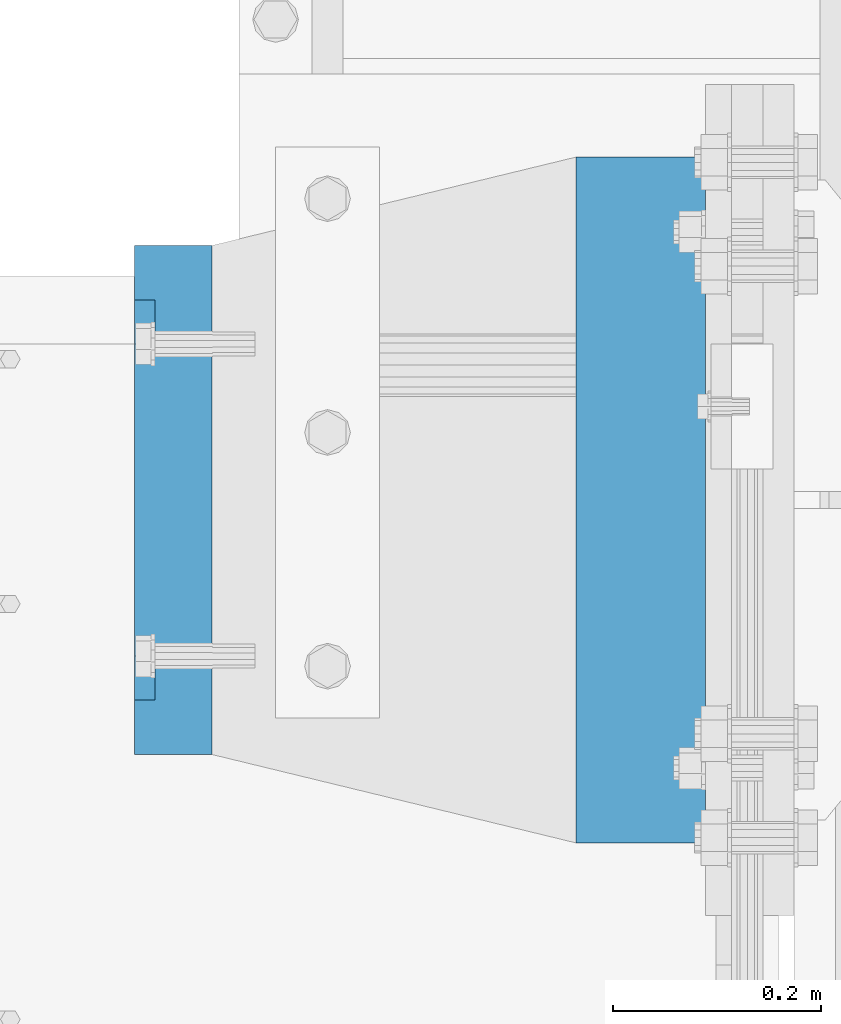
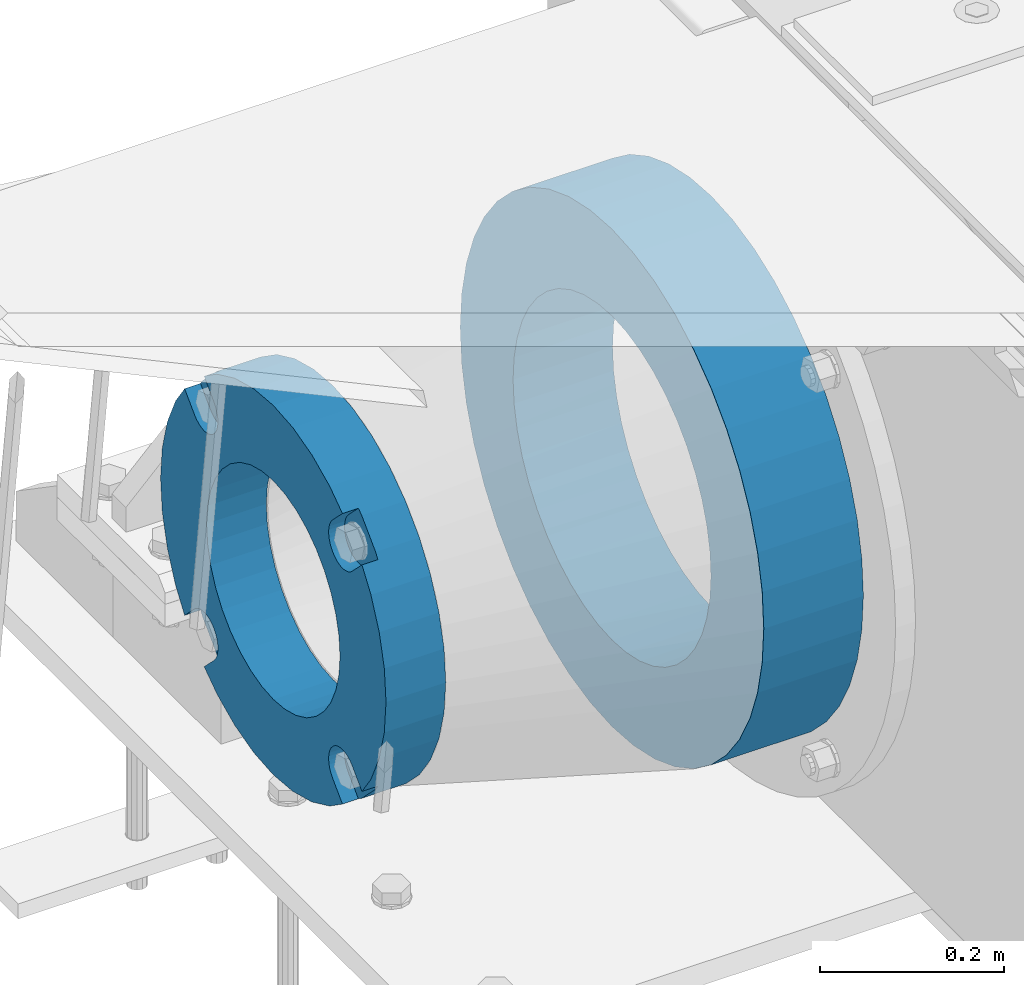
# One storey, part 136 of 219: 2 beams.
"""IFC2X3 building model written with IfcOpenShell, lengths in millimetres."""

from ifc_helpers import new_model, si_unit, frame, origin_with_axes, place, context, subcontext, project, spatial, faceted_brep, material, type_object, element, save


model = new_model("IFC2X3")

# Units and contexts
model_context = context("Model", 3, precision=1e-05, world=origin_with_axes())
body_context = subcontext(model_context, "Body", "Model", "MODEL_VIEW")
ifc_project = project(units=[si_unit("LENGTHUNIT", "METRE", prefix="MILLI"), si_unit("AREAUNIT", "SQUARE_METRE"), si_unit("VOLUMEUNIT", "CUBIC_METRE"), si_unit("MASSUNIT", "GRAM", prefix="KILO"), si_unit("TIMEUNIT", "SECOND"), si_unit("PLANEANGLEUNIT", "RADIAN"), si_unit("SOLIDANGLEUNIT", "STERADIAN"), si_unit("THERMODYNAMICTEMPERATUREUNIT", "DEGREE_CELSIUS"), si_unit("LUMINOUSINTENSITYUNIT", "LUMEN")], contexts=[model_context])

# Site, building, storey
site_placement = place(None, origin_with_axes())
site = spatial("IfcSite", under=ifc_project, at=site_placement, CompositionType="ELEMENT")
building_placement = place(site_placement, origin_with_axes())
building = spatial("IfcBuilding", under=site, at=building_placement, Name="Standard", CompositionType="ELEMENT")
storey_placement = place(building_placement, origin_with_axes())
storey = spatial("IfcBuildingStorey", under=building, at=storey_placement, Name="Undefined", CompositionType="ELEMENT", Elevation=0.0)

# Beams
ifc_material_1 = material(Name="SCN-500-E2")
beam_type_1 = type_object("IfcBeamType", PredefinedType="NOTDEFINED")
beam_1_placement = place(storey_placement, frame((-550.0, 33000.0000014662, -515.0), z_axis=(0.0, 0.0, 1.0), x_axis=(-1.0, 0.0, 0.0)))
element("IfcBeam", 1, at=beam_1_placement, inside=storey, type_object=beam_type_1, material=ifc_material_1, context=body_context, shape_type="Brep", body=[
    faceted_brep([(75.0, 192.717024793295, -150.290616455866), (75.0000000000001, 171.473395903973, -129.046987566545), (55.0000000000002, 171.473395903973, -129.046987566545), (55.0000000000002, 192.717024793295, -150.290616455865), (75.0000000000001, 167.467485559311, -125.685629673395), (55.0000000000002, 167.467485559311, -125.685629673395), (75.0000000000001, 162.938740320955, -123.070957391003), (55.0000000000002, 162.938740320955, -123.070957391003), (75.0000000000001, 158.024763821777, -121.282416213472), (55.0000000000002, 158.024763821777, -121.282416213472), (75.0000000000001, 152.874864751095, -120.374350059435), (55.0000000000002, 152.874864751095, -120.374350059435), (75.0000000000001, 147.645520186205, -120.374350059479), (55.0000000000002, 147.645520186205, -120.374350059479), (75.0000000000001, 142.495621115537, -121.282416213595), (55.0000000000002, 142.495621115537, -121.282416213595), (75.0000000000001, 137.581644616374, -123.070957391204), (55.0000000000002, 137.581644616374, -123.070957391204), (75.0, 133.052899378039, -125.685629673665), (55.0000000000002, 133.052899378039, -125.685629673665), (75.0, 129.04698903278, -129.046987566545), (55.0000000000002, 129.04698903278, -129.046987566545), (75.0, 125.685631139982, -133.05289791162), (55.0000000000002, 125.685631139982, -133.05289791162), (75.0, 123.070958857592, -137.581643149926), (55.0000000000002, 123.070958857592, -137.581643149926), (75.0, 121.28241768005, -142.49561964906), (55.0000000000002, 121.28241768005, -142.49561964906), (75.0, 120.374351525992, -147.64551871968), (55.0000000000002, 120.374351525992, -147.64551871968), (75.0, 120.374351525999, -152.874863284513), (55.0000000000002, 120.374351525999, -152.874863284513), (75.0, 121.282417680093, -158.024762355132), (55.0000000000002, 121.282417680093, -158.024762355132), (75.0, 123.070958857665, -162.938738854251), (55.0000000000002, 123.070958857665, -162.938738854251), (75.0, 125.685631140077, -167.467484092545), (55.0000000000002, 125.685631140077, -167.467484092545), (75.0, 129.04698903278, -171.473394437738), (55.0000000000002, 129.04698903278, -171.473394437738), (55.0000000000002, 150.290618180639, -192.717023585594), (75.0, 150.290618180639, -192.717023585598), (55.0000000000002, 157.482964373201, -187.68088856415), (55.0000000000002, 187.680888564151, -157.482964373202), (75.0, -192.717023585596, 150.290618180639), (75.0, -171.4733929715, 129.046987566545), (55.0000000000002, -171.4733929715, 129.046987566545), (55.0000000000002, -192.717023585596, 150.290618180638), (75.0, -167.467482626838, 125.685629673395), (55.0000000000002, -167.467482626838, 125.685629673395), (75.0, -162.938737388482, 123.070957391003), (55.0000000000002, -162.938737388482, 123.070957391003), (75.0, -158.024760889304, 121.282416213472), (55.0000000000002, -158.024760889304, 121.282416213472), (75.0, -152.874861818622, 120.374350059435), (55.0000000000002, -152.874861818622, 120.374350059435), (75.0, -147.645517253732, 120.374350059479), (55.0000000000002, -147.645517253732, 120.374350059479), (75.0, -142.495618183064, 121.282416213595), (55.0000000000002, -142.495618183064, 121.282416213595), (75.0, -137.581641683901, 123.070957391204), (55.0000000000002, -137.581641683901, 123.070957391204), (75.0, -133.052896445566, 125.685629673665), (55.0000000000002, -133.052896445566, 125.685629673665), (75.0, -129.046986100308, 129.046987566545), (55.0000000000002, -129.046986100308, 129.046987566545), (75.0, -125.68562820751, 133.05289791162), (55.0000000000002, -125.68562820751, 133.05289791162), (75.0, -123.070955925119, 137.581643149926), (55.0000000000002, -123.070955925119, 137.581643149926), (75.0, -121.282414747577, 142.49561964906), (55.0000000000002, -121.282414747577, 142.49561964906), (75.0, -120.374348593519, 147.64551871968), (55.0000000000002, -120.374348593519, 147.64551871968), (75.0, -120.374348593527, 152.874863284513), (55.0000000000002, -120.374348593527, 152.874863284513), (75.0, -121.28241474762, 158.024762355132), (55.0000000000002, -121.28241474762, 158.024762355132), (75.0, -123.070955925192, 162.938738854251), (55.0000000000002, -123.070955925192, 162.938738854251), (75.0, -125.685628207604, 167.467484092545), (55.0000000000002, -125.685628207604, 167.467484092545), (75.0, -129.046986100308, 171.473394437738), (55.0000000000002, -129.046986100308, 171.473394437738), (55.0000000000002, -150.290616455859, 192.717024793291), (75.0, -150.290616455866, 192.717024793295), (75.0, 150.290618180639, 192.717023585596), (75.0000000000002, 129.04698903278, 171.473394437739), (55.0000000000002, 129.04698903278, 171.473394437739), (55.0000000000002, 150.290618180632, 192.717023585593), (75.0000000000002, 125.685631139633, 167.467484093078), (55.0000000000002, 125.685631139633, 167.467484093078), (75.0000000000002, 123.070958857235, 162.938738854723), (55.0000000000002, 123.070958857235, 162.938738854723), (75.0000000000002, 121.282417679708, 158.024762355545), (55.0000000000002, 121.282417679708, 158.024762355545), (75.0000000000002, 120.374351525672, 152.874863284862), (55.0000000000002, 120.374351525672, 152.874863284862), (75.0000000000002, 120.374351525716, 147.645518719972), (55.0000000000002, 120.374351525716, 147.645518719972), (75.0000000000002, 121.282417679831, 142.495619649306), (55.0000000000002, 121.282417679831, 142.495619649306), (75.0000000000002, 123.070958857439, 137.581643150138), (55.0000000000002, 123.070958857439, 137.581643150138), (75.0000000000002, 125.685631139902, 133.052897911806), (55.0000000000002, 125.685631139902, 133.052897911806), (75.0000000000002, 129.04698903278, 129.046987566546), (55.0000000000002, 129.04698903278, 129.046987566546), (75.0000000000002, 133.052899377857, 125.685629673749), (55.0000000000002, 133.052899377857, 125.685629673749), (75.0000000000002, 137.581644616163, 123.070957391354), (55.0000000000002, 137.581644616163, 123.070957391354), (75.0000000000002, 142.495621115297, 121.282416213815), (55.0000000000002, 142.495621115297, 121.282416213815), (75.0000000000002, 147.645520185913, 120.374350059761), (55.0000000000002, 147.645520185913, 120.374350059761), (75.0000000000002, 152.874864750745, 120.374350059768), (55.0000000000002, 152.874864750745, 120.374350059768), (75.0000000000002, 158.02476382137, 121.282416213859), (55.0000000000002, 158.02476382137, 121.282416213859), (75.0000000000002, 162.938740320489, 123.070957391429), (55.0000000000002, 162.938740320489, 123.070957391429), (75.0000000000002, 167.46748555878, 125.685629673842), (55.0000000000002, 167.46748555878, 125.685629673842), (75.0000000000002, 171.473395903973, 129.046987566546), (55.0000000000002, 171.473395903973, 129.046987566546), (55.0000000000002, 192.717024793295, 150.290616455867), (75.0, 192.717024793295, 150.290616455871), (0.0, 212.176223927185, -122.5), (0.0, 230.224692092546, -83.7949351147888), (75.0, 230.224692092546, -83.7949351147888), (75.0, 212.176223927185, -122.5), (0.0, 241.277899487992, -42.5438035283978), (75.0, 241.277899487992, -42.5438035283978), (0.0, 245.0, 0.0), (75.0, 245.0, 0.0), (0.0, 241.277899487992, 42.543803528398), (75.0, 241.277899487992, 42.543803528398), (0.0, 230.224692092546, 83.7949351147889), (75.0, 230.224692092546, 83.7949351147889), (0.0, 212.176223927185, 122.5), (75.0, 212.176223927185, 122.5), (0.0, 187.680888564151, 157.482964373202), (55.0000000000002, 187.680888564151, 157.482964373202), (0.0, 157.482964373201, 187.68088856415), (55.0000000000002, 157.482964373201, 187.68088856415), (0.0, 122.5, 212.176223927187), (75.0, 122.5, 212.176223927187), (0.0, 83.7949351147909, 230.224692092548), (75.0, 83.7949351147909, 230.224692092548), (0.0, 42.5438035283951, 241.277899487991), (75.0, 42.5438035283951, 241.277899487991), (0.0, 0.0, 245.0), (75.0, 0.0, 245.0), (0.0, -42.5438035283951, 241.277899487991), (75.0, -42.5438035283951, 241.277899487991), (0.0, -83.7949351147909, 230.224692092548), (75.0, -83.7949351147909, 230.224692092548), (0.0, -122.5, 212.176223927187), (75.0, -122.5, 212.176223927187), (0.0, -157.482964373201, 187.68088856415), (55.0000000000002, -157.482964373201, 187.68088856415), (0.0, -187.680888564151, 157.482964373202), (55.0000000000002, -187.680888564151, 157.482964373202), (0.0, -212.176223927185, 122.5), (75.0, -212.176223927185, 122.5), (0.0, -230.224692092546, 83.7949351147888), (75.0, -230.224692092546, 83.7949351147888), (0.0, -241.277899487992, 42.5438035283979), (75.0, -241.277899487992, 42.5438035283979), (0.0, -245.0, 0.0), (75.0, -245.0, 0.0), (0.0, -187.680888564151, -157.482964373202), (0.0, -157.482964373201, -187.68088856415), (55.0000000000002, -157.482964373201, -187.68088856415), (55.0000000000002, -187.680888564151, -157.482964373202), (0.0, 83.7949351147909, -230.224692092547), (0.0, 122.5, -212.176223927187), (75.0, 122.5, -212.176223927187), (75.0, 83.7949351147909, -230.224692092547), (0.0, 42.5438035283951, -241.277899487991), (75.0, 42.5438035283951, -241.277899487991), (0.0, 0.0, -245.0), (75.0, 0.0, -245.0), (0.0, -42.5438035283951, -241.277899487991), (75.0, -42.5438035283951, -241.277899487991), (0.0, -83.7949351147909, -230.224692092548), (75.0, -83.7949351147909, -230.224692092548), (0.0, -122.5, -212.176223927187), (75.0, -122.5, -212.176223927187), (75.0, -150.290616455866, -192.717024793295), (55.0000000000002, -150.290616455866, -192.717024793296), (55.0000000000002, -129.046986100308, -171.473394437739), (55.0000000000002, -125.68562820716, -167.467484093078), (55.0000000000002, -123.070955924763, -162.938738854723), (55.0000000000002, -121.282414747235, -158.024762355545), (55.0000000000002, -120.374348593199, -152.874863284861), (55.0000000000002, -120.374348593243, -147.645518719972), (55.0000000000002, -121.282414747358, -142.495619649306), (55.0000000000002, -123.070955924966, -137.581643150138), (55.0000000000002, -125.68562820743, -133.052897911806), (55.0000000000002, -129.046986100308, -129.046987566546), (55.0000000000002, -133.052896445384, -125.685629673749), (55.0000000000002, -137.58164168369, -123.070957391354), (55.0000000000002, -142.495618182824, -121.282416213815), (55.0000000000002, -147.645517253441, -120.374350059761), (55.0000000000002, -152.874861818273, -120.374350059768), (55.0000000000002, -158.024760888897, -121.282416213859), (55.0000000000002, -162.938737388016, -123.070957391429), (55.0000000000002, -167.467482626307, -125.685629673842), (55.0000000000002, -171.4733929715, -129.046987566546), (55.0000000000002, -192.717023585596, -150.290618180637), (75.0, -129.046986100308, -171.473394437739), (75.0, -125.68562820716, -167.467484093078), (75.0, -123.070955924763, -162.938738854723), (75.0, -121.282414747235, -158.024762355545), (75.0, -120.374348593199, -152.874863284861), (75.0, -120.374348593243, -147.645518719972), (75.0, -121.282414747358, -142.495619649306), (75.0, -123.070955924966, -137.581643150138), (75.0, -125.68562820743, -133.052897911806), (75.0, -129.046986100308, -129.046987566546), (75.0, -133.052896445384, -125.685629673749), (75.0, -137.58164168369, -123.070957391354), (75.0, -142.495618182824, -121.282416213815), (75.0, -147.645517253441, -120.374350059761), (75.0, -152.874861818273, -120.374350059768), (75.0, -158.024760888897, -121.282416213859), (75.0, -162.938737388016, -123.070957391429), (75.0, -167.467482626307, -125.685629673842), (75.0, -171.4733929715, -129.046987566546), (75.0, -192.717023585596, -150.29061818064), (75.0, -212.176223927185, -122.5), (0.0, -212.176223927185, -122.5), (0.0, -230.224692092546, -83.794935114789), (75.0, -230.224692092546, -83.794935114789), (0.0, -241.277899487992, -42.5438035283979), (75.0, -241.277899487992, -42.5438035283979), (0.0, 187.680888564151, -157.482964373202), (0.0, 157.482964373201, -187.68088856415), (0.0, -142.797124186771, -25.1789857617049), (0.0, -136.25543001396, -49.592920782222), (0.0, -125.573683548741, -72.5), (0.0, -111.076444252249, -93.2042034045483), (0.0, -93.2042034045517, -111.076444252252), (0.0, -72.5, -125.573683548744), (0.0, -49.5929207822192, -136.255430013957), (0.0, -25.1789857617041, -142.79712418677), (0.0, 0.0, -145.0), (0.0, 25.1789857617041, -142.79712418677), (0.0, 49.5929207822192, -136.255430013957), (0.0, 72.5, -125.573683548744), (0.0, 93.2042034045517, -111.076444252252), (0.0, 111.076444252249, -93.2042034045483), (0.0, 125.573683548741, -72.5), (0.0, 136.25543001396, -49.592920782222), (0.0, 142.797124186771, -25.178985761705), (0.0, 145.0, 0.0), (0.0, 142.797124186771, 25.1789857617048), (0.0, 136.25543001396, 49.5929207822219), (0.0, 125.573683548741, 72.4999999999999), (0.0, 111.076444252249, 93.2042034045482), (0.0, 93.2042034045517, 111.076444252252), (0.0, 72.5, 125.573683548744), (0.0, 49.5929207822192, 136.255430013957), (0.0, 25.1789857617041, 142.79712418677), (0.0, 0.0, 145.0), (0.0, -25.1789857617041, 142.79712418677), (0.0, -49.5929207822192, 136.255430013957), (0.0, -72.5, 125.573683548744), (0.0, -93.2042034045517, 111.076444252252), (0.0, -111.076444252249, 93.2042034045483), (0.0, -125.573683548741, 72.5000000000001), (0.0, -136.25543001396, 49.5929207822221), (0.0, -142.797124186771, 25.1789857617049), (0.0, -145.0, 0.0), (75.0, -145.0, 0.0), (75.0, -142.797124186771, -25.1789857617049), (75.0, -136.25543001396, -49.592920782222), (75.0, -125.573683548741, -72.5), (75.0, -111.076444252249, -93.2042034045483), (75.0, -93.2042034045517, -111.076444252252), (75.0, -72.5, -125.573683548744), (75.0, -49.5929207822192, -136.255430013957), (75.0, -25.1789857617041, -142.79712418677), (75.0, 0.0, -145.0), (75.0, 25.1789857617041, -142.79712418677), (75.0, 49.5929207822192, -136.255430013957), (75.0, 72.5, -125.573683548744), (75.0, 93.2042034045517, -111.076444252252), (75.0, 111.076444252249, -93.2042034045483), (75.0, 125.573683548741, -72.5), (75.0, 136.25543001396, -49.592920782222), (75.0, 142.797124186771, -25.178985761705), (75.0, 145.0, 0.0), (75.0, 142.797124186771, 25.1789857617048), (75.0, 136.25543001396, 49.5929207822219), (75.0, 125.573683548741, 72.4999999999999), (75.0, 111.076444252249, 93.2042034045482), (75.0, 93.2042034045517, 111.076444252252), (75.0, 72.5, 125.573683548744), (75.0, 49.5929207822192, 136.255430013957), (75.0, 25.1789857617041, 142.79712418677), (75.0, 0.0, 145.0), (75.0, -25.1789857617041, 142.79712418677), (75.0, -49.5929207822192, 136.255430013957), (75.0, -72.5, 125.573683548744), (75.0, -93.2042034045517, 111.076444252252), (75.0, -111.076444252249, 93.2042034045483), (75.0, -125.573683548741, 72.5000000000001), (75.0, -136.25543001396, 49.5929207822221), (75.0, -142.797124186771, 25.1789857617049)], [[[0, 1, 2, 3]], [[4, 5, 2, 1]], [[6, 7, 5, 4]], [[8, 9, 7, 6]], [[10, 11, 9, 8]], [[12, 13, 11, 10]], [[14, 15, 13, 12]], [[16, 17, 15, 14]], [[18, 19, 17, 16]], [[20, 21, 19, 18]], [[22, 23, 21, 20]], [[24, 25, 23, 22]], [[26, 27, 25, 24]], [[28, 29, 27, 26]], [[30, 31, 29, 28]], [[32, 33, 31, 30]], [[34, 35, 33, 32]], [[36, 37, 35, 34]], [[38, 39, 37, 36]], [[40, 39, 38, 41]], [[42, 43, 3, 2, 5, 7, 9, 11, 13, 15, 17, 19, 21, 23, 25, 27, 29, 31, 33, 35, 37, 39, 40]], [[44, 45, 46, 47]], [[48, 49, 46, 45]], [[50, 51, 49, 48]], [[52, 53, 51, 50]], [[54, 55, 53, 52]], [[56, 57, 55, 54]], [[58, 59, 57, 56]], [[60, 61, 59, 58]], [[62, 63, 61, 60]], [[64, 65, 63, 62]], [[66, 67, 65, 64]], [[68, 69, 67, 66]], [[70, 71, 69, 68]], [[72, 73, 71, 70]], [[74, 75, 73, 72]], [[76, 77, 75, 74]], [[78, 79, 77, 76]], [[80, 81, 79, 78]], [[82, 83, 81, 80]], [[84, 83, 82, 85]], [[86, 87, 88, 89]], [[90, 91, 88, 87]], [[92, 93, 91, 90]], [[94, 95, 93, 92]], [[96, 97, 95, 94]], [[98, 99, 97, 96]], [[100, 101, 99, 98]], [[102, 103, 101, 100]], [[104, 105, 103, 102]], [[106, 107, 105, 104]], [[108, 109, 107, 106]], [[110, 111, 109, 108]], [[112, 113, 111, 110]], [[114, 115, 113, 112]], [[116, 117, 115, 114]], [[118, 119, 117, 116]], [[120, 121, 119, 118]], [[122, 123, 121, 120]], [[124, 125, 123, 122]], [[126, 125, 124, 127]], [[128, 129, 130, 131]], [[129, 132, 133, 130]], [[132, 134, 135, 133]], [[134, 136, 137, 135]], [[136, 138, 139, 137]], [[138, 140, 141, 139]], [[127, 141, 140, 142, 143, 126]], [[142, 144, 145, 143]], [[89, 88, 91, 93, 95, 97, 99, 101, 103, 105, 107, 109, 111, 113, 115, 117, 119, 121, 123, 125, 126, 143, 145]], [[144, 146, 147, 86, 89, 145]], [[146, 148, 149, 147]], [[148, 150, 151, 149]], [[150, 152, 153, 151]], [[152, 154, 155, 153]], [[154, 156, 157, 155]], [[156, 158, 159, 157]], [[85, 159, 158, 160, 161, 84]], [[160, 162, 163, 161]], [[47, 46, 49, 51, 53, 55, 57, 59, 61, 63, 65, 67, 69, 71, 73, 75, 77, 79, 81, 83, 84, 161, 163]], [[162, 164, 165, 44, 47, 163]], [[164, 166, 167, 165]], [[166, 168, 169, 167]], [[168, 170, 171, 169]], [[172, 173, 174, 175]], [[176, 177, 178, 179]], [[180, 176, 179, 181]], [[182, 180, 181, 183]], [[184, 182, 183, 185]], [[186, 184, 185, 187]], [[188, 186, 187, 189]], [[173, 188, 189, 190, 191, 174]], [[175, 174, 191, 192, 193, 194, 195, 196, 197, 198, 199, 200, 201, 202, 203, 204, 205, 206, 207, 208, 209, 210, 211]], [[190, 212, 192, 191]], [[213, 193, 192, 212]], [[214, 194, 193, 213]], [[215, 195, 194, 214]], [[216, 196, 195, 215]], [[217, 197, 196, 216]], [[218, 198, 197, 217]], [[219, 199, 198, 218]], [[220, 200, 199, 219]], [[221, 201, 200, 220]], [[222, 202, 201, 221]], [[223, 203, 202, 222]], [[224, 204, 203, 223]], [[225, 205, 204, 224]], [[226, 206, 205, 225]], [[227, 207, 206, 226]], [[228, 208, 207, 227]], [[229, 209, 208, 228]], [[230, 210, 209, 229]], [[211, 210, 230, 231]], [[232, 233, 172, 175, 211, 231]], [[234, 233, 232, 235]], [[236, 234, 235, 237]], [[170, 236, 237, 171]], [[168, 166, 164, 162, 160, 158, 156, 154, 152, 150, 148, 146, 144, 142, 140, 138, 136, 134, 132, 129, 128, 238, 239, 177, 176, 180, 182, 184, 186, 188, 173, 172, 233, 234, 236, 170], [240, 241, 242, 243, 244, 245, 246, 247, 248, 249, 250, 251, 252, 253, 254, 255, 256, 257, 258, 259, 260, 261, 262, 263, 264, 265, 266, 267, 268, 269, 270, 271, 272, 273, 274, 275]], [[240, 275, 276, 277]], [[241, 240, 277, 278]], [[242, 241, 278, 279]], [[243, 242, 279, 280]], [[244, 243, 280, 281]], [[245, 244, 281, 282]], [[246, 245, 282, 283]], [[247, 246, 283, 284]], [[248, 247, 284, 285]], [[249, 248, 285, 286]], [[250, 249, 286, 287]], [[251, 250, 287, 288]], [[252, 251, 288, 289]], [[253, 252, 289, 290]], [[254, 253, 290, 291]], [[255, 254, 291, 292]], [[256, 255, 292, 293]], [[257, 256, 293, 294]], [[258, 257, 294, 295]], [[259, 258, 295, 296]], [[260, 259, 296, 297]], [[261, 260, 297, 298]], [[262, 261, 298, 299]], [[263, 262, 299, 300]], [[264, 263, 300, 301]], [[265, 264, 301, 302]], [[266, 265, 302, 303]], [[267, 266, 303, 304]], [[268, 267, 304, 305]], [[269, 268, 305, 306]], [[270, 269, 306, 307]], [[271, 270, 307, 308]], [[272, 271, 308, 309]], [[273, 272, 309, 310]], [[274, 273, 310, 311]], [[275, 274, 311, 276]], [[24, 22, 20, 18, 16, 14, 12, 10, 8, 6, 4, 1, 0, 131, 130, 133, 135, 137, 139, 141, 127, 124, 122, 120, 118, 116, 114, 112, 110, 108, 106, 104, 102, 100, 98, 96, 94, 92, 90, 87, 86, 147, 149, 151, 153, 155, 157, 159, 85, 82, 80, 78, 76, 74, 72, 70, 68, 66, 64, 62, 60, 58, 56, 54, 52, 50, 48, 45, 44, 165, 167, 169, 171, 237, 235, 232, 231, 230, 229, 228, 227, 226, 225, 224, 223, 222, 221, 220, 219, 218, 217, 216, 215, 214, 213, 212, 190, 189, 187, 185, 183, 181, 179, 178, 41, 38, 36, 34, 32, 30, 28, 26], [310, 309, 308, 307, 306, 305, 304, 303, 302, 301, 300, 299, 298, 297, 296, 295, 294, 293, 292, 291, 290, 289, 288, 287, 286, 285, 284, 283, 282, 281, 280, 279, 278, 277, 276, 311]], [[238, 128, 131, 0, 3, 43]], [[239, 238, 43, 42]], [[178, 177, 239, 42, 40, 41]]]),
])
ifc_material_2 = material(Name="STEEL/S355N")
beam_type_2 = type_object("IfcBeamType", PredefinedType="NOTDEFINED")
beam_2_placement = place(storey_placement, frame((-74.999999999991, 33000.0, -515.0), z_axis=(0.0, 0.0, 1.0), x_axis=(-1.0, 0.0, 0.0)))
element("IfcBeam", 2, at=beam_2_placement, inside=storey, type_object=beam_type_2, material=ifc_material_2, context=body_context, shape_type="Brep", body=[
    faceted_brep([(0.0, -215.0, 0.0), (0.0, -212.811610004399, 30.5976902287563), (125.0, -212.811610004399, 30.5976902287563), (125.0, -215.0, 0.0), (0.0, -206.290989327113, 60.5724997209074), (125.0, -206.290989327113, 60.5724997209074), (0.0, -195.570879001221, 89.3142277954056), (125.0, -195.570879001221, 89.3142277954056), (0.0, -180.869509558703, 116.237775752953), (125.0, -180.869509558703, 116.237775752953), (0.0, -162.486158486165, 140.795057798236), (125.0, -162.486158486165, 140.795057798236), (0.0, -140.795057798234, 162.486158486165), (125.0, -140.795057798234, 162.486158486165), (0.0, -116.237775752954, 180.869509558704), (125.0, -116.237775752954, 180.869509558704), (0.0, -89.314227795403, 195.570879001222), (125.0, -89.314227795403, 195.570879001222), (0.0, -60.5724997209109, 206.290989327117), (125.0, -60.5724997209109, 206.290989327117), (0.0, -30.5976902287584, 212.811610004401), (125.0, -30.5976902287584, 212.811610004401), (0.0, 0.0, 215.0), (125.0, 0.0, 215.0), (0.0, 30.5976902287584, 212.811610004401), (125.0, 30.5976902287584, 212.811610004401), (0.0, 60.5724997209109, 206.290989327117), (125.0, 60.5724997209109, 206.290989327117), (0.0, 89.314227795403, 195.570879001221), (125.0, 89.314227795403, 195.570879001221), (0.0, 116.237775752954, 180.869509558704), (125.0, 116.237775752954, 180.869509558704), (0.0, 140.795057798234, 162.486158486165), (125.0, 140.795057798234, 162.486158486165), (0.0, 162.486158486165, 140.795057798236), (125.0, 162.486158486165, 140.795057798236), (0.0, 180.869509558703, 116.237775752953), (125.0, 180.869509558703, 116.237775752953), (0.0, 195.570879001221, 89.3142277954056), (125.0, 195.570879001221, 89.3142277954056), (0.0, 206.290989327113, 60.5724997209073), (125.0, 206.290989327113, 60.5724997209073), (0.0, 212.811610004399, 30.5976902287563), (125.0, 212.811610004399, 30.5976902287563), (0.0, 215.0, 0.0), (125.0, 215.0, 0.0), (0.0, 212.811610004399, -30.5976902287563), (125.0, 212.811610004399, -30.5976902287563), (0.0, 206.290989327113, -60.5724997209073), (125.0, 206.290989327113, -60.5724997209073), (0.0, 195.570879001221, -89.3142277954056), (125.0, 195.570879001221, -89.3142277954056), (0.0, 180.869509558703, -116.237775752954), (125.0, 180.869509558703, -116.237775752954), (0.0, 162.486158486165, -140.795057798236), (125.0, 162.486158486165, -140.795057798236), (0.0, 140.795057798234, -162.486158486166), (125.0, 140.795057798234, -162.486158486166), (0.0, 116.237775752954, -180.869509558704), (125.0, 116.237775752954, -180.869509558704), (0.0, 89.314227795403, -195.570879001221), (125.0, 89.314227795403, -195.570879001221), (0.0, 60.5724997209109, -206.290989327117), (125.0, 60.5724997209109, -206.290989327117), (0.0, 30.5976902287584, -212.811610004401), (125.0, 30.5976902287584, -212.811610004401), (0.0, 0.0, -215.0), (125.0, 0.0, -215.0), (0.0, -30.5976902287584, -212.811610004401), (125.0, -30.5976902287584, -212.811610004401), (0.0, -60.5724997209109, -206.290989327117), (125.0, -60.5724997209109, -206.290989327117), (0.0, -89.314227795403, -195.570879001221), (125.0, -89.314227795403, -195.570879001221), (0.0, -116.237775752954, -180.869509558704), (125.0, -116.237775752954, -180.869509558704), (0.0, -140.795057798234, -162.486158486166), (125.0, -140.795057798234, -162.486158486166), (0.0, -162.486158486165, -140.795057798236), (125.0, -162.486158486165, -140.795057798236), (0.0, -180.869509558703, -116.237775752953), (125.0, -180.869509558703, -116.237775752953), (0.0, -195.570879001221, -89.3142277954056), (125.0, -195.570879001221, -89.3142277954056), (0.0, -206.290989327113, -60.5724997209073), (125.0, -206.290989327113, -60.5724997209073), (0.0, -212.811610004399, -30.5976902287563), (125.0, -212.811610004399, -30.5976902287563), (0.0, -330.0, 0.0), (0.0, -326.641075820706, -46.9638966301842), (125.0, -326.641075820706, -46.9638966301842), (125.0, -330.0, 0.0), (0.0, -316.632681292787, -92.9717437576718), (125.0, -316.632681292787, -92.9717437576718), (0.0, -300.178558466992, -137.086954290623), (125.0, -300.178558466992, -137.086954290623), (0.0, -277.613665834288, -178.411469760347), (125.0, -277.613665834288, -178.411469760347), (0.0, -249.397359536903, -216.104042201944), (125.0, -249.397359536903, -216.104042201944), (0.0, -216.104042201943, -249.397359536905), (125.0, -216.104042201943, -249.397359536905), (0.0, -178.411469760344, -277.61366583429), (125.0, -178.411469760344, -277.61366583429), (0.0, -137.086954290622, -300.178558466991), (125.0, -137.086954290622, -300.178558466991), (0.0, -92.9717437576692, -316.632681292784), (125.0, -92.9717437576692, -316.632681292784), (0.0, -46.9638966301864, -326.641075820708), (125.0, -46.9638966301864, -326.641075820708), (0.0, 0.0, -330.0), (125.0, 0.0, -330.0), (0.0, 46.9638966301864, -326.641075820708), (125.0, 46.9638966301864, -326.641075820708), (0.0, 92.9717437576692, -316.632681292784), (125.0, 92.9717437576692, -316.632681292784), (0.0, 137.086954290622, -300.178558466991), (125.0, 137.086954290622, -300.178558466991), (0.0, 178.411469760344, -277.61366583429), (125.0, 178.411469760344, -277.61366583429), (0.0, 216.104042201943, -249.397359536905), (125.0, 216.104042201943, -249.397359536905), (0.0, 249.397359536906, -216.104042201944), (125.0, 249.397359536906, -216.104042201944), (0.0, 277.613665834291, -178.411469760347), (125.0, 277.613665834291, -178.411469760347), (0.0, 300.178558466992, -137.086954290623), (125.0, 300.178558466992, -137.086954290623), (0.0, 316.632681292784, -92.9717437576717), (125.0, 316.632681292784, -92.9717437576717), (0.0, 326.641075820709, -46.9638966301841), (125.0, 326.641075820709, -46.9638966301841), (0.0, 330.0, 0.0), (125.0, 330.0, 0.0), (0.0, 326.641075820709, 46.9638966301841), (125.0, 326.641075820709, 46.9638966301841), (0.0, 316.632681292784, 92.9717437576718), (125.0, 316.632681292784, 92.9717437576718), (0.0, 300.178558466992, 137.086954290622), (125.0, 300.178558466992, 137.086954290622), (0.0, 277.613665834291, 178.411469760347), (125.0, 277.613665834291, 178.411469760347), (0.0, 249.397359536906, 216.104042201944), (125.0, 249.397359536906, 216.104042201944), (0.0, 216.104042201943, 249.397359536905), (125.0, 216.104042201943, 249.397359536905), (0.0, 178.411469760344, 277.61366583429), (125.0, 178.411469760344, 277.61366583429), (0.0, 137.086954290622, 300.178558466991), (125.0, 137.086954290622, 300.178558466991), (0.0, 92.9717437576692, 316.632681292784), (125.0, 92.9717437576692, 316.632681292784), (0.0, 46.9638966301864, 326.641075820708), (125.0, 46.9638966301864, 326.641075820708), (0.0, 0.0, 330.0), (125.0, 0.0, 330.0), (0.0, -46.9638966301864, 326.641075820708), (125.0, -46.9638966301864, 326.641075820708), (0.0, -92.9717437576692, 316.632681292784), (125.0, -92.9717437576692, 316.632681292784), (0.0, -137.086954290622, 300.178558466991), (125.0, -137.086954290622, 300.178558466991), (0.0, -178.411469760344, 277.61366583429), (125.0, -178.411469760344, 277.61366583429), (0.0, -216.104042201943, 249.397359536905), (125.0, -216.104042201943, 249.397359536905), (0.0, -249.397359536903, 216.104042201944), (125.0, -249.397359536903, 216.104042201944), (0.0, -277.613665834288, 178.411469760347), (125.0, -277.613665834288, 178.411469760347), (0.0, -300.178558466992, 137.086954290623), (125.0, -300.178558466992, 137.086954290623), (0.0, -316.632681292787, 92.9717437576718), (125.0, -316.632681292787, 92.9717437576718), (0.0, -326.641075820706, 46.9638966301841), (125.0, -326.641075820706, 46.9638966301841)], [[[0, 1, 2, 3]], [[1, 4, 5, 2]], [[4, 6, 7, 5]], [[6, 8, 9, 7]], [[8, 10, 11, 9]], [[10, 12, 13, 11]], [[12, 14, 15, 13]], [[14, 16, 17, 15]], [[16, 18, 19, 17]], [[18, 20, 21, 19]], [[20, 22, 23, 21]], [[22, 24, 25, 23]], [[24, 26, 27, 25]], [[26, 28, 29, 27]], [[28, 30, 31, 29]], [[30, 32, 33, 31]], [[32, 34, 35, 33]], [[34, 36, 37, 35]], [[36, 38, 39, 37]], [[38, 40, 41, 39]], [[40, 42, 43, 41]], [[42, 44, 45, 43]], [[44, 46, 47, 45]], [[46, 48, 49, 47]], [[48, 50, 51, 49]], [[50, 52, 53, 51]], [[52, 54, 55, 53]], [[54, 56, 57, 55]], [[56, 58, 59, 57]], [[58, 60, 61, 59]], [[60, 62, 63, 61]], [[62, 64, 65, 63]], [[64, 66, 67, 65]], [[66, 68, 69, 67]], [[68, 70, 71, 69]], [[70, 72, 73, 71]], [[72, 74, 75, 73]], [[74, 76, 77, 75]], [[76, 78, 79, 77]], [[78, 80, 81, 79]], [[80, 82, 83, 81]], [[82, 84, 85, 83]], [[84, 86, 87, 85]], [[86, 0, 3, 87]], [[88, 89, 90, 91]], [[89, 92, 93, 90]], [[92, 94, 95, 93]], [[94, 96, 97, 95]], [[96, 98, 99, 97]], [[98, 100, 101, 99]], [[100, 102, 103, 101]], [[102, 104, 105, 103]], [[104, 106, 107, 105]], [[106, 108, 109, 107]], [[108, 110, 111, 109]], [[110, 112, 113, 111]], [[112, 114, 115, 113]], [[114, 116, 117, 115]], [[116, 118, 119, 117]], [[118, 120, 121, 119]], [[120, 122, 123, 121]], [[122, 124, 125, 123]], [[124, 126, 127, 125]], [[126, 128, 129, 127]], [[128, 130, 131, 129]], [[130, 132, 133, 131]], [[132, 134, 135, 133]], [[134, 136, 137, 135]], [[136, 138, 139, 137]], [[138, 140, 141, 139]], [[140, 142, 143, 141]], [[142, 144, 145, 143]], [[144, 146, 147, 145]], [[146, 148, 149, 147]], [[148, 150, 151, 149]], [[150, 152, 153, 151]], [[152, 154, 155, 153]], [[154, 156, 157, 155]], [[156, 158, 159, 157]], [[158, 160, 161, 159]], [[160, 162, 163, 161]], [[162, 164, 165, 163]], [[164, 166, 167, 165]], [[166, 168, 169, 167]], [[168, 170, 171, 169]], [[170, 172, 173, 171]], [[172, 174, 175, 173]], [[174, 88, 91, 175]], [[93, 95, 97, 99, 101, 103, 105, 107, 109, 111, 113, 115, 117, 119, 121, 123, 125, 127, 129, 131, 133, 135, 137, 139, 141, 143, 145, 147, 149, 151, 153, 155, 157, 159, 161, 163, 165, 167, 169, 171, 173, 175, 91, 90], [5, 7, 9, 11, 13, 15, 17, 19, 21, 23, 25, 27, 29, 31, 33, 35, 37, 39, 41, 43, 45, 47, 49, 51, 53, 55, 57, 59, 61, 63, 65, 67, 69, 71, 73, 75, 77, 79, 81, 83, 85, 87, 3, 2]], [[174, 172, 170, 168, 166, 164, 162, 160, 158, 156, 154, 152, 150, 148, 146, 144, 142, 140, 138, 136, 134, 132, 130, 128, 126, 124, 122, 120, 118, 116, 114, 112, 110, 108, 106, 104, 102, 100, 98, 96, 94, 92, 89, 88], [86, 84, 82, 80, 78, 76, 74, 72, 70, 68, 66, 64, 62, 60, 58, 56, 54, 52, 50, 48, 46, 44, 42, 40, 38, 36, 34, 32, 30, 28, 26, 24, 22, 20, 18, 16, 14, 12, 10, 8, 6, 4, 1, 0]]]),
])

save(model, "model.ifc")
